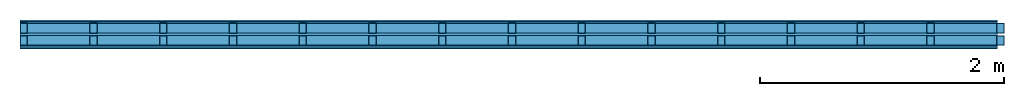
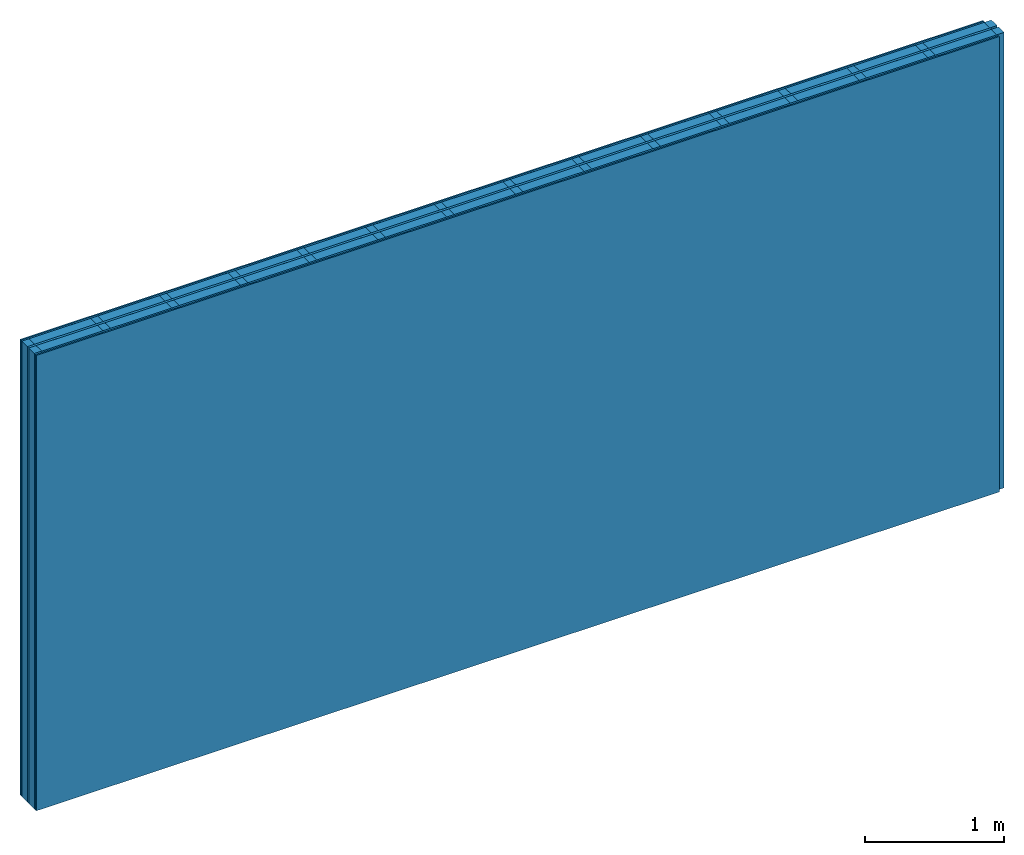
# One storey: 5 plates, 4 members, 1 element without a shape of its own.
"""IFC4 building model written with IfcOpenShell, lengths in metres."""

from ifc_helpers import new_model, si_unit, derived_unit, direction, frame, frame_2d, origin, origin_with_axes, place, context, project, spatial, rectangle, extrude, material, layer, layer_set, type_object, element, aggregate, save


model = new_model("IFC4")

# Units and contexts
plan_context = context("Plan", 3, precision=1e-05, world=origin(), true_north=direction((0.0, 1.0)))
model_context = context("Model", 3, precision=1e-05, world=origin(), true_north=direction((0.0, 1.0)))
ifc_project = project(units=[si_unit("LENGTHUNIT", "METRE"), derived_unit("SOUNDPRESSUREUNIT", [(si_unit("PRESSUREUNIT", "PASCAL", prefix="MICRO"), 0)]), si_unit("ENERGYUNIT", "JOULE", prefix="MEGA"), si_unit("MASSUNIT", "GRAM", prefix="KILO"), derived_unit("THERMALTRANSMITTANCEUNIT", [(si_unit("POWERUNIT", "WATT"), 1), (si_unit("AREAUNIT", "SQUARE_METRE"), -1), (si_unit("THERMODYNAMICTEMPERATUREUNIT", "KELVIN"), -1)]), derived_unit("AREADENSITYUNIT", [(si_unit("MASSUNIT", "GRAM", prefix="KILO"), 1), (si_unit("AREAUNIT", "SQUARE_METRE"), -1)]), derived_unit("USERDEFINED", [(si_unit("ENERGYUNIT", "JOULE", prefix="MEGA"), 1), (si_unit("AREAUNIT", "SQUARE_METRE"), -1)])], contexts=[plan_context, model_context])

# Site, building, storey
site = spatial("IfcSite", under=ifc_project)
building_placement = place(None, origin())
building = spatial("IfcBuilding", under=site, at=building_placement)
storey_placement = place(building_placement, origin())
storey = spatial("IfcBuildingStorey", under=building, at=storey_placement)

# Wall, members, plates
ifc_material_1 = material(Name="Glued joints")
ifc_layer_1 = layer(ifc_material_1, 0.0, Name="Surface")
ifc_material_2 = material(Category="03.008")
ifc_layer_2 = layer(ifc_material_2, 0.0125, Name="room side 2nd layer")
ifc_material_3 = material(Name="LivingBoard face P5", Category="07.015")
ifc_layer_3 = layer(ifc_material_3, 0.015, Name="room side 1st layer")
ifc_layer_4 = layer(None, 0.08, Name="Support")
ifc_material_4 = material(Name="of the art")
ifc_layer_5 = layer(ifc_material_4, 0.0, Name="Bond")
ifc_material_5 = material(Name="Air")
ifc_layer_6 = layer(ifc_material_5, 0.02, Name="Air gap")
ifc_layer_7 = layer(ifc_material_4, 0.0, Name="Bond")
ifc_layer_8 = layer(None, 0.08, Name="Support")
ifc_layer_9 = layer(ifc_material_3, 0.015, Name="room side 1st layer")
ifc_layer_10 = layer(ifc_material_2, 0.0125, Name="room side 2nd layer")
ifc_layer_set = layer_set([ifc_layer_1, ifc_layer_2, ifc_layer_3, ifc_layer_4, ifc_layer_5, ifc_layer_6, ifc_layer_7, ifc_layer_8, ifc_layer_9, ifc_layer_10])
wall_type = type_object("IfcWallType", Name="B9403", PredefinedType="NOTDEFINED", material=ifc_layer_set)
wall_placement = place(None, frame((0.0, 0.0, 0.0), z_axis=(0.0, -1.0, 0.0), x_axis=(1.0, 0.0, 0.0)))
wall = element("IfcWall", 1, at=wall_placement, inside=storey, type_object=wall_type, material=ifc_layer_set, Name="Wall #1")
ifc_material_6 = material()
member_1_placement = place(wall_placement, origin())
member_1 = element("IfcMember", 2, at=member_1_placement, material=ifc_material_6, Name="Support", context=plan_context, shape_type="SweptSolid", body=[
    extrude(rectangle(XDim=0.06, YDim=0.08, at=frame_2d((0.03, 0.04), x_axis=(1.0, 0.0))), frame((0.0, 4.0, 0.0275), z_axis=(0.0, -1.0, 0.0), x_axis=(1.0, 0.0, 0.0)), (0.0, 0.0, 1.0), 4.0),
    extrude(rectangle(XDim=0.06, YDim=0.08, at=frame_2d((0.03, 0.04), x_axis=(1.0, 0.0))), frame((0.571, 4.0, 0.0275), z_axis=(0.0, -1.0, 0.0), x_axis=(1.0, 0.0, 0.0)), (0.0, 0.0, 1.0), 4.0),
    extrude(rectangle(XDim=0.06, YDim=0.08, at=frame_2d((0.03, 0.04), x_axis=(1.0, 0.0))), frame((1.142, 4.0, 0.0275), z_axis=(0.0, -1.0, 0.0), x_axis=(1.0, 0.0, 0.0)), (0.0, 0.0, 1.0), 4.0),
    extrude(rectangle(XDim=0.06, YDim=0.08, at=frame_2d((0.03, 0.04), x_axis=(1.0, 0.0))), frame((1.713, 4.0, 0.0275), z_axis=(0.0, -1.0, 0.0), x_axis=(1.0, 0.0, 0.0)), (0.0, 0.0, 1.0), 4.0),
    extrude(rectangle(XDim=0.06, YDim=0.08, at=frame_2d((0.03, 0.04), x_axis=(1.0, 0.0))), frame((2.284, 4.0, 0.0275), z_axis=(0.0, -1.0, 0.0), x_axis=(1.0, 0.0, 0.0)), (0.0, 0.0, 1.0), 4.0),
    extrude(rectangle(XDim=0.06, YDim=0.08, at=frame_2d((0.03, 0.04), x_axis=(1.0, 0.0))), frame((2.855, 4.0, 0.0275), z_axis=(0.0, -1.0, 0.0), x_axis=(1.0, 0.0, 0.0)), (0.0, 0.0, 1.0), 4.0),
    extrude(rectangle(XDim=0.06, YDim=0.08, at=frame_2d((0.03, 0.04), x_axis=(1.0, 0.0))), frame((3.426, 4.0, 0.0275), z_axis=(0.0, -1.0, 0.0), x_axis=(1.0, 0.0, 0.0)), (0.0, 0.0, 1.0), 4.0),
    extrude(rectangle(XDim=0.06, YDim=0.08, at=frame_2d((0.03, 0.04), x_axis=(1.0, 0.0))), frame((3.997, 4.0, 0.0275), z_axis=(0.0, -1.0, 0.0), x_axis=(1.0, 0.0, 0.0)), (0.0, 0.0, 1.0), 4.0),
    extrude(rectangle(XDim=0.06, YDim=0.08, at=frame_2d((0.03, 0.04), x_axis=(1.0, 0.0))), frame((4.568, 4.0, 0.0275), z_axis=(0.0, -1.0, 0.0), x_axis=(1.0, 0.0, 0.0)), (0.0, 0.0, 1.0), 4.0),
    extrude(rectangle(XDim=0.06, YDim=0.08, at=frame_2d((0.03, 0.04), x_axis=(1.0, 0.0))), frame((5.139, 4.0, 0.0275), z_axis=(0.0, -1.0, 0.0), x_axis=(1.0, 0.0, 0.0)), (0.0, 0.0, 1.0), 4.0),
    extrude(rectangle(XDim=0.06, YDim=0.08, at=frame_2d((0.03, 0.04), x_axis=(1.0, 0.0))), frame((5.71, 4.0, 0.0275), z_axis=(0.0, -1.0, 0.0), x_axis=(1.0, 0.0, 0.0)), (0.0, 0.0, 1.0), 4.0),
    extrude(rectangle(XDim=0.06, YDim=0.08, at=frame_2d((0.03, 0.04), x_axis=(1.0, 0.0))), frame((6.281, 4.0, 0.0275), z_axis=(0.0, -1.0, 0.0), x_axis=(1.0, 0.0, 0.0)), (0.0, 0.0, 1.0), 4.0),
    extrude(rectangle(XDim=0.06, YDim=0.08, at=frame_2d((0.03, 0.04), x_axis=(1.0, 0.0))), frame((6.852, 4.0, 0.0275), z_axis=(0.0, -1.0, 0.0), x_axis=(1.0, 0.0, 0.0)), (0.0, 0.0, 1.0), 4.0),
    extrude(rectangle(XDim=0.06, YDim=0.08, at=frame_2d((0.03, 0.04), x_axis=(1.0, 0.0))), frame((7.423, 4.0, 0.0275), z_axis=(0.0, -1.0, 0.0), x_axis=(1.0, 0.0, 0.0)), (0.0, 0.0, 1.0), 4.0),
    extrude(rectangle(XDim=0.06, YDim=0.08, at=frame_2d((0.03, 0.04), x_axis=(1.0, 0.0))), frame((7.994, 4.0, 0.0275), z_axis=(0.0, -1.0, 0.0), x_axis=(1.0, 0.0, 0.0)), (0.0, 0.0, 1.0), 4.0),
])
ifc_material_7 = material()
member_2_placement = place(wall_placement, origin())
member_2 = element("IfcMember", 3, at=member_2_placement, material=ifc_material_7, Name="Cavity", context=plan_context, shape_type="SweptSolid", body=[
    extrude(rectangle(XDim=0.511, YDim=0.08, at=frame_2d((0.2555, 0.04), x_axis=(1.0, 0.0))), frame((0.06, 4.0, 0.0275), z_axis=(0.0, -1.0, 0.0), x_axis=(1.0, 0.0, 0.0)), (0.0, 0.0, 1.0), 4.0),
    extrude(rectangle(XDim=0.511, YDim=0.08, at=frame_2d((0.2555, 0.04), x_axis=(1.0, 0.0))), frame((0.631, 4.0, 0.0275), z_axis=(0.0, -1.0, 0.0), x_axis=(1.0, 0.0, 0.0)), (0.0, 0.0, 1.0), 4.0),
    extrude(rectangle(XDim=0.511, YDim=0.08, at=frame_2d((0.2555, 0.04), x_axis=(1.0, 0.0))), frame((1.202, 4.0, 0.0275), z_axis=(0.0, -1.0, 0.0), x_axis=(1.0, 0.0, 0.0)), (0.0, 0.0, 1.0), 4.0),
    extrude(rectangle(XDim=0.511, YDim=0.08, at=frame_2d((0.2555, 0.04), x_axis=(1.0, 0.0))), frame((1.773, 4.0, 0.0275), z_axis=(0.0, -1.0, 0.0), x_axis=(1.0, 0.0, 0.0)), (0.0, 0.0, 1.0), 4.0),
    extrude(rectangle(XDim=0.511, YDim=0.08, at=frame_2d((0.2555, 0.04), x_axis=(1.0, 0.0))), frame((2.344, 4.0, 0.0275), z_axis=(0.0, -1.0, 0.0), x_axis=(1.0, 0.0, 0.0)), (0.0, 0.0, 1.0), 4.0),
    extrude(rectangle(XDim=0.511, YDim=0.08, at=frame_2d((0.2555, 0.04), x_axis=(1.0, 0.0))), frame((2.915, 4.0, 0.0275), z_axis=(0.0, -1.0, 0.0), x_axis=(1.0, 0.0, 0.0)), (0.0, 0.0, 1.0), 4.0),
    extrude(rectangle(XDim=0.511, YDim=0.08, at=frame_2d((0.2555, 0.04), x_axis=(1.0, 0.0))), frame((3.486, 4.0, 0.0275), z_axis=(0.0, -1.0, 0.0), x_axis=(1.0, 0.0, 0.0)), (0.0, 0.0, 1.0), 4.0),
    extrude(rectangle(XDim=0.511, YDim=0.08, at=frame_2d((0.2555, 0.04), x_axis=(1.0, 0.0))), frame((4.057, 4.0, 0.0275), z_axis=(0.0, -1.0, 0.0), x_axis=(1.0, 0.0, 0.0)), (0.0, 0.0, 1.0), 4.0),
    extrude(rectangle(XDim=0.511, YDim=0.08, at=frame_2d((0.2555, 0.04), x_axis=(1.0, 0.0))), frame((4.628, 4.0, 0.0275), z_axis=(0.0, -1.0, 0.0), x_axis=(1.0, 0.0, 0.0)), (0.0, 0.0, 1.0), 4.0),
    extrude(rectangle(XDim=0.511, YDim=0.08, at=frame_2d((0.2555, 0.04), x_axis=(1.0, 0.0))), frame((5.199, 4.0, 0.0275), z_axis=(0.0, -1.0, 0.0), x_axis=(1.0, 0.0, 0.0)), (0.0, 0.0, 1.0), 4.0),
    extrude(rectangle(XDim=0.511, YDim=0.08, at=frame_2d((0.2555, 0.04), x_axis=(1.0, 0.0))), frame((5.77, 4.0, 0.0275), z_axis=(0.0, -1.0, 0.0), x_axis=(1.0, 0.0, 0.0)), (0.0, 0.0, 1.0), 4.0),
    extrude(rectangle(XDim=0.511, YDim=0.08, at=frame_2d((0.2555, 0.04), x_axis=(1.0, 0.0))), frame((6.341, 4.0, 0.0275), z_axis=(0.0, -1.0, 0.0), x_axis=(1.0, 0.0, 0.0)), (0.0, 0.0, 1.0), 4.0),
    extrude(rectangle(XDim=0.511, YDim=0.08, at=frame_2d((0.2555, 0.04), x_axis=(1.0, 0.0))), frame((6.912, 4.0, 0.0275), z_axis=(0.0, -1.0, 0.0), x_axis=(1.0, 0.0, 0.0)), (0.0, 0.0, 1.0), 4.0),
    extrude(rectangle(XDim=0.511, YDim=0.08, at=frame_2d((0.2555, 0.04), x_axis=(1.0, 0.0))), frame((7.483, 4.0, 0.0275), z_axis=(0.0, -1.0, 0.0), x_axis=(1.0, 0.0, 0.0)), (0.0, 0.0, 1.0), 4.0),
])
member_3_placement = place(wall_placement, origin())
member_3 = element("IfcMember", 4, at=member_3_placement, material=ifc_material_6, Name="Support", context=plan_context, shape_type="SweptSolid", body=[
    extrude(rectangle(XDim=0.06, YDim=0.08, at=frame_2d((0.03, 0.04), x_axis=(1.0, 0.0))), frame((0.0, 4.0, 0.1275), z_axis=(0.0, -1.0, 0.0), x_axis=(1.0, 0.0, 0.0)), (0.0, 0.0, 1.0), 4.0),
    extrude(rectangle(XDim=0.06, YDim=0.08, at=frame_2d((0.03, 0.04), x_axis=(1.0, 0.0))), frame((0.571, 4.0, 0.1275), z_axis=(0.0, -1.0, 0.0), x_axis=(1.0, 0.0, 0.0)), (0.0, 0.0, 1.0), 4.0),
    extrude(rectangle(XDim=0.06, YDim=0.08, at=frame_2d((0.03, 0.04), x_axis=(1.0, 0.0))), frame((1.142, 4.0, 0.1275), z_axis=(0.0, -1.0, 0.0), x_axis=(1.0, 0.0, 0.0)), (0.0, 0.0, 1.0), 4.0),
    extrude(rectangle(XDim=0.06, YDim=0.08, at=frame_2d((0.03, 0.04), x_axis=(1.0, 0.0))), frame((1.713, 4.0, 0.1275), z_axis=(0.0, -1.0, 0.0), x_axis=(1.0, 0.0, 0.0)), (0.0, 0.0, 1.0), 4.0),
    extrude(rectangle(XDim=0.06, YDim=0.08, at=frame_2d((0.03, 0.04), x_axis=(1.0, 0.0))), frame((2.284, 4.0, 0.1275), z_axis=(0.0, -1.0, 0.0), x_axis=(1.0, 0.0, 0.0)), (0.0, 0.0, 1.0), 4.0),
    extrude(rectangle(XDim=0.06, YDim=0.08, at=frame_2d((0.03, 0.04), x_axis=(1.0, 0.0))), frame((2.855, 4.0, 0.1275), z_axis=(0.0, -1.0, 0.0), x_axis=(1.0, 0.0, 0.0)), (0.0, 0.0, 1.0), 4.0),
    extrude(rectangle(XDim=0.06, YDim=0.08, at=frame_2d((0.03, 0.04), x_axis=(1.0, 0.0))), frame((3.426, 4.0, 0.1275), z_axis=(0.0, -1.0, 0.0), x_axis=(1.0, 0.0, 0.0)), (0.0, 0.0, 1.0), 4.0),
    extrude(rectangle(XDim=0.06, YDim=0.08, at=frame_2d((0.03, 0.04), x_axis=(1.0, 0.0))), frame((3.997, 4.0, 0.1275), z_axis=(0.0, -1.0, 0.0), x_axis=(1.0, 0.0, 0.0)), (0.0, 0.0, 1.0), 4.0),
    extrude(rectangle(XDim=0.06, YDim=0.08, at=frame_2d((0.03, 0.04), x_axis=(1.0, 0.0))), frame((4.568, 4.0, 0.1275), z_axis=(0.0, -1.0, 0.0), x_axis=(1.0, 0.0, 0.0)), (0.0, 0.0, 1.0), 4.0),
    extrude(rectangle(XDim=0.06, YDim=0.08, at=frame_2d((0.03, 0.04), x_axis=(1.0, 0.0))), frame((5.139, 4.0, 0.1275), z_axis=(0.0, -1.0, 0.0), x_axis=(1.0, 0.0, 0.0)), (0.0, 0.0, 1.0), 4.0),
    extrude(rectangle(XDim=0.06, YDim=0.08, at=frame_2d((0.03, 0.04), x_axis=(1.0, 0.0))), frame((5.71, 4.0, 0.1275), z_axis=(0.0, -1.0, 0.0), x_axis=(1.0, 0.0, 0.0)), (0.0, 0.0, 1.0), 4.0),
    extrude(rectangle(XDim=0.06, YDim=0.08, at=frame_2d((0.03, 0.04), x_axis=(1.0, 0.0))), frame((6.281, 4.0, 0.1275), z_axis=(0.0, -1.0, 0.0), x_axis=(1.0, 0.0, 0.0)), (0.0, 0.0, 1.0), 4.0),
    extrude(rectangle(XDim=0.06, YDim=0.08, at=frame_2d((0.03, 0.04), x_axis=(1.0, 0.0))), frame((6.852, 4.0, 0.1275), z_axis=(0.0, -1.0, 0.0), x_axis=(1.0, 0.0, 0.0)), (0.0, 0.0, 1.0), 4.0),
    extrude(rectangle(XDim=0.06, YDim=0.08, at=frame_2d((0.03, 0.04), x_axis=(1.0, 0.0))), frame((7.423, 4.0, 0.1275), z_axis=(0.0, -1.0, 0.0), x_axis=(1.0, 0.0, 0.0)), (0.0, 0.0, 1.0), 4.0),
    extrude(rectangle(XDim=0.06, YDim=0.08, at=frame_2d((0.03, 0.04), x_axis=(1.0, 0.0))), frame((7.994, 4.0, 0.1275), z_axis=(0.0, -1.0, 0.0), x_axis=(1.0, 0.0, 0.0)), (0.0, 0.0, 1.0), 4.0),
])
member_4_placement = place(wall_placement, origin())
member_4 = element("IfcMember", 5, at=member_4_placement, material=ifc_material_7, Name="Cavity", context=plan_context, shape_type="SweptSolid", body=[
    extrude(rectangle(XDim=0.511, YDim=0.08, at=frame_2d((0.2555, 0.04), x_axis=(1.0, 0.0))), frame((0.06, 4.0, 0.1275), z_axis=(0.0, -1.0, 0.0), x_axis=(1.0, 0.0, 0.0)), (0.0, 0.0, 1.0), 4.0),
    extrude(rectangle(XDim=0.511, YDim=0.08, at=frame_2d((0.2555, 0.04), x_axis=(1.0, 0.0))), frame((0.631, 4.0, 0.1275), z_axis=(0.0, -1.0, 0.0), x_axis=(1.0, 0.0, 0.0)), (0.0, 0.0, 1.0), 4.0),
    extrude(rectangle(XDim=0.511, YDim=0.08, at=frame_2d((0.2555, 0.04), x_axis=(1.0, 0.0))), frame((1.202, 4.0, 0.1275), z_axis=(0.0, -1.0, 0.0), x_axis=(1.0, 0.0, 0.0)), (0.0, 0.0, 1.0), 4.0),
    extrude(rectangle(XDim=0.511, YDim=0.08, at=frame_2d((0.2555, 0.04), x_axis=(1.0, 0.0))), frame((1.773, 4.0, 0.1275), z_axis=(0.0, -1.0, 0.0), x_axis=(1.0, 0.0, 0.0)), (0.0, 0.0, 1.0), 4.0),
    extrude(rectangle(XDim=0.511, YDim=0.08, at=frame_2d((0.2555, 0.04), x_axis=(1.0, 0.0))), frame((2.344, 4.0, 0.1275), z_axis=(0.0, -1.0, 0.0), x_axis=(1.0, 0.0, 0.0)), (0.0, 0.0, 1.0), 4.0),
    extrude(rectangle(XDim=0.511, YDim=0.08, at=frame_2d((0.2555, 0.04), x_axis=(1.0, 0.0))), frame((2.915, 4.0, 0.1275), z_axis=(0.0, -1.0, 0.0), x_axis=(1.0, 0.0, 0.0)), (0.0, 0.0, 1.0), 4.0),
    extrude(rectangle(XDim=0.511, YDim=0.08, at=frame_2d((0.2555, 0.04), x_axis=(1.0, 0.0))), frame((3.486, 4.0, 0.1275), z_axis=(0.0, -1.0, 0.0), x_axis=(1.0, 0.0, 0.0)), (0.0, 0.0, 1.0), 4.0),
    extrude(rectangle(XDim=0.511, YDim=0.08, at=frame_2d((0.2555, 0.04), x_axis=(1.0, 0.0))), frame((4.057, 4.0, 0.1275), z_axis=(0.0, -1.0, 0.0), x_axis=(1.0, 0.0, 0.0)), (0.0, 0.0, 1.0), 4.0),
    extrude(rectangle(XDim=0.511, YDim=0.08, at=frame_2d((0.2555, 0.04), x_axis=(1.0, 0.0))), frame((4.628, 4.0, 0.1275), z_axis=(0.0, -1.0, 0.0), x_axis=(1.0, 0.0, 0.0)), (0.0, 0.0, 1.0), 4.0),
    extrude(rectangle(XDim=0.511, YDim=0.08, at=frame_2d((0.2555, 0.04), x_axis=(1.0, 0.0))), frame((5.199, 4.0, 0.1275), z_axis=(0.0, -1.0, 0.0), x_axis=(1.0, 0.0, 0.0)), (0.0, 0.0, 1.0), 4.0),
    extrude(rectangle(XDim=0.511, YDim=0.08, at=frame_2d((0.2555, 0.04), x_axis=(1.0, 0.0))), frame((5.77, 4.0, 0.1275), z_axis=(0.0, -1.0, 0.0), x_axis=(1.0, 0.0, 0.0)), (0.0, 0.0, 1.0), 4.0),
    extrude(rectangle(XDim=0.511, YDim=0.08, at=frame_2d((0.2555, 0.04), x_axis=(1.0, 0.0))), frame((6.341, 4.0, 0.1275), z_axis=(0.0, -1.0, 0.0), x_axis=(1.0, 0.0, 0.0)), (0.0, 0.0, 1.0), 4.0),
    extrude(rectangle(XDim=0.511, YDim=0.08, at=frame_2d((0.2555, 0.04), x_axis=(1.0, 0.0))), frame((6.912, 4.0, 0.1275), z_axis=(0.0, -1.0, 0.0), x_axis=(1.0, 0.0, 0.0)), (0.0, 0.0, 1.0), 4.0),
    extrude(rectangle(XDim=0.511, YDim=0.08, at=frame_2d((0.2555, 0.04), x_axis=(1.0, 0.0))), frame((7.483, 4.0, 0.1275), z_axis=(0.0, -1.0, 0.0), x_axis=(1.0, 0.0, 0.0)), (0.0, 0.0, 1.0), 4.0),
])
plate_1_placement = place(wall_placement, origin())
plate_1 = element("IfcPlate", 6, at=plate_1_placement, material=ifc_material_2, Name="room side 2nd layer", context=plan_context, shape_type="SweptSolid", body=[
    extrude(rectangle(XDim=8.0, YDim=4.0, at=frame_2d((4.0, 2.0), x_axis=(1.0, 0.0))), origin_with_axes(), (0.0, 0.0, 1.0), 0.0125),
])
plate_2_placement = place(wall_placement, origin())
plate_2 = element("IfcPlate", 7, at=plate_2_placement, material=ifc_material_3, Name="room side 1st layer", context=plan_context, shape_type="SweptSolid", body=[
    extrude(rectangle(XDim=8.0, YDim=4.0, at=frame_2d((4.0, 2.0), x_axis=(1.0, 0.0))), frame((0.0, 0.0, 0.0125), z_axis=(0.0, 0.0, 1.0), x_axis=(1.0, 0.0, 0.0)), (0.0, 0.0, 1.0), 0.015),
])
plate_3_placement = place(wall_placement, origin())
plate_3 = element("IfcPlate", 8, at=plate_3_placement, material=ifc_material_5, Name="Air gap", context=plan_context, shape_type="SweptSolid", body=[
    extrude(rectangle(XDim=8.0, YDim=4.0, at=frame_2d((4.0, 2.0), x_axis=(1.0, 0.0))), frame((0.0, 0.0, 0.1075), z_axis=(0.0, 0.0, 1.0), x_axis=(1.0, 0.0, 0.0)), (0.0, 0.0, 1.0), 0.02),
])
plate_4_placement = place(wall_placement, origin())
plate_4 = element("IfcPlate", 9, at=plate_4_placement, material=ifc_material_3, Name="room side 1st layer", context=plan_context, shape_type="SweptSolid", body=[
    extrude(rectangle(XDim=8.0, YDim=4.0, at=frame_2d((4.0, 2.0), x_axis=(1.0, 0.0))), frame((0.0, 0.0, 0.2075), z_axis=(0.0, 0.0, 1.0), x_axis=(1.0, 0.0, 0.0)), (0.0, 0.0, 1.0), 0.015),
])
plate_5_placement = place(wall_placement, origin())
plate_5 = element("IfcPlate", 10, at=plate_5_placement, material=ifc_material_2, Name="room side 2nd layer", context=plan_context, shape_type="SweptSolid", body=[
    extrude(rectangle(XDim=8.0, YDim=4.0, at=frame_2d((4.0, 2.0), x_axis=(1.0, 0.0))), frame((0.0, 0.0, 0.2225), z_axis=(0.0, 0.0, 1.0), x_axis=(1.0, 0.0, 0.0)), (0.0, 0.0, 1.0), 0.0125),
])
aggregate(wall, [plate_1, plate_2, member_1, member_2, plate_3, member_3, member_4, plate_4, plate_5])

save(model, "model.ifc")
